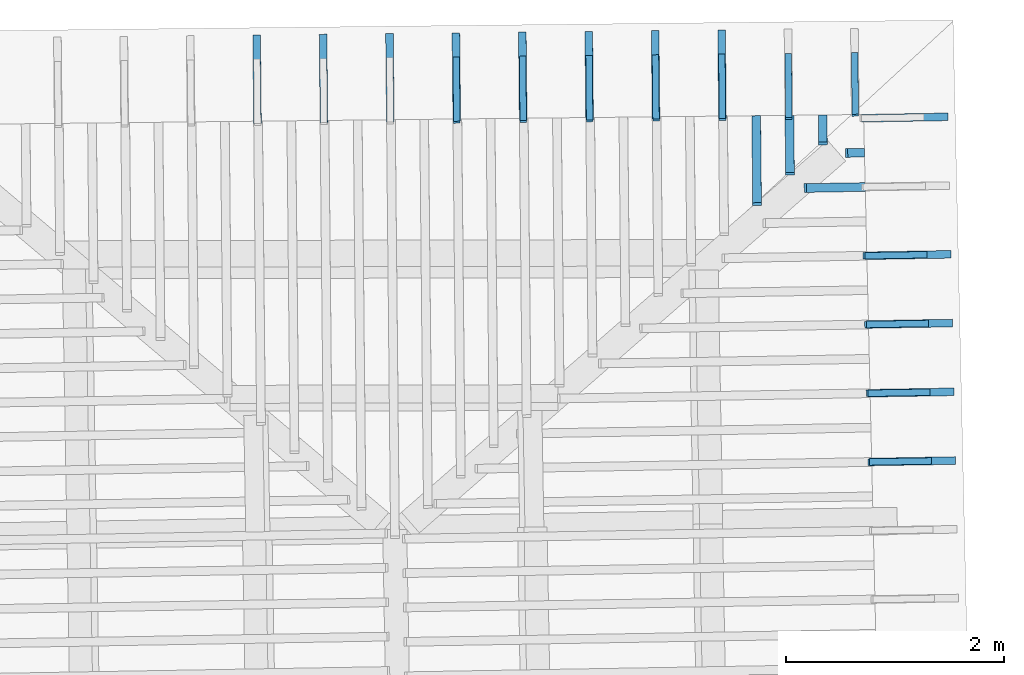
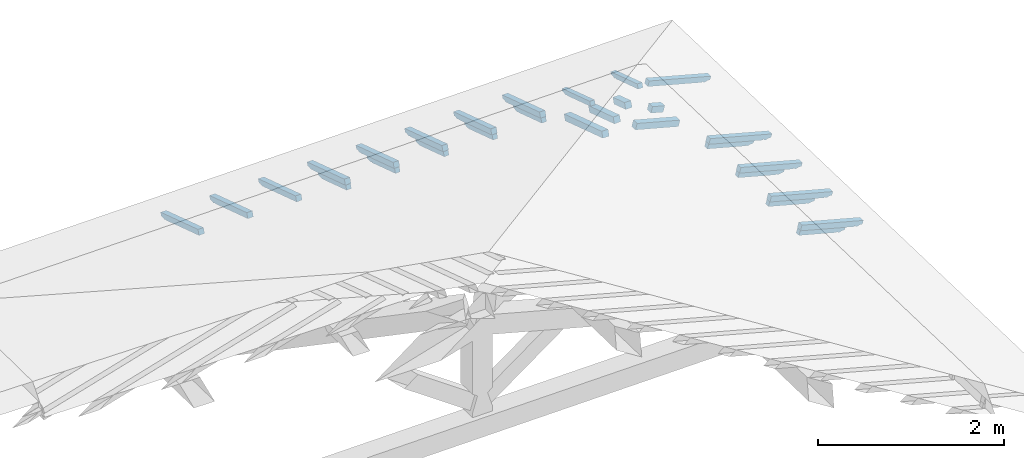
# One storey, part 16 of 19: 29 beams, 6 elements without a shape of their own.
"""IFC4 building model written with IfcOpenShell, lengths in metres."""

from ifc_helpers import new_model, entity, si_unit, converted_unit, derived_unit, direction, frame, origin, place, context, subcontext, project, spatial, line, arc, indexed_curve, outline, extrude, source, transform, mapped, material, type_object, type_shapes, element, aggregate, save


model = new_model("IFC4")

# Units and contexts
model_context = context("Model", 3, precision=1e-05, world=origin(), true_north=direction((6.123233995736766e-17, 1.0)))
body_context = subcontext(model_context, "Body", "Model", "MODEL_VIEW")
ifc_project = project(units=[si_unit("LENGTHUNIT", "METRE"), si_unit("AREAUNIT", "SQUARE_METRE"), si_unit("VOLUMEUNIT", "CUBIC_METRE"), converted_unit("PLANEANGLEUNIT", "DEGREE", entity("IfcPlaneAngleMeasure", 0.017453292519943278), si_unit("PLANEANGLEUNIT", "RADIAN"), dimensions=[0, 0, 0, 0, 0, 0, 0]), derived_unit("THERMALTRANSMITTANCEUNIT", [(si_unit("MASSUNIT", "GRAM", prefix="KILO"), 1), (si_unit("THERMODYNAMICTEMPERATUREUNIT", "KELVIN"), -1), (si_unit("TIMEUNIT", "SECOND"), -3)])], contexts=[model_context])

# Site, building, storey
site_placement = place(None, origin())
site = spatial("IfcSite", under=ifc_project, at=site_placement, CompositionType="ELEMENT")
building_placement = place(site_placement, origin())
building = spatial("IfcBuilding", under=site, at=building_placement, CompositionType="ELEMENT")
storey_placement = place(building_placement, frame((0.0, 0.0, 3.28)))
storey = spatial("IfcBuildingStorey", under=building, at=storey_placement, Name="Livello Copertura", CompositionType="ELEMENT", Elevation=3.28)

# Assembly, beams
assembly_1_placement = place(storey_placement, origin())
assembly_1 = element("IfcElementAssembly", 1, at=assembly_1_placement, inside=storey, Name="Sistema di travi strutturali:Sistema di travi strutturali", ObjectType="Sistema di travi strutturali:Sistema di travi strutturali", AssemblyPlace="NOTDEFINED", PredefinedType="BEAM_GRID")
ifc_material = material(Name="Legno - Legno da costruzione", Category="Legno")
beam_type_1 = type_object("IfcBeamType", Name="Legno:80x80", PredefinedType="JOIST", material=ifc_material)
shared_shape_1 = source(origin(), body_context, "Body", "SweptSolid", [
    extrude(outline(indexed_curve([(-0.279, -0.04000000000000169), (0.279, -0.04000000000000169), (0.279, 0.04000000000000169), (-0.279, 0.04000000000000169), (-0.279, -0.04000000000000169)], self_intersect=False)), frame((0.0, 0.0, -0.040000000000005476), z_axis=(0.0, 0.0, 1.0), x_axis=(-1.0, 0.0, 0.0)), (0.0, 0.0, 1.0), 0.07999999999999997),
])
type_shapes(beam_type_1, [shared_shape_1])
beam_1_placement = place(assembly_1_placement, frame((3.7267769633071848, 15.508499100327318, 0.1833482961653332), z_axis=(0.2688805697492533, 0.004594467440668275, 0.9631625667976583), x_axis=(-0.9630219859926787, -0.01645553326302891, 0.2689198206152652)))
beam_1 = element("IfcBeam", 2, at=beam_1_placement, type_object=beam_type_1, material=ifc_material, Name="Legno:80x80", ObjectType="Legno:80x80", PredefinedType="JOIST", context=body_context, shape_type="MappedRepresentation", body=[
    mapped(shared_shape_1, transform((0.0, 0.0, 0.0), scale=1.0)),
])
beam_type_2 = type_object("IfcBeamType", Name="Legno:80x80", PredefinedType="JOIST", material=ifc_material)
shared_shape_2 = source(origin(), body_context, "Body", "SweptSolid", [
    extrude(outline(indexed_curve([(-0.0795, -0.04000000000000169), (0.0795, -0.04000000000000169), (0.0795, 0.04000000000000169), (-0.0795, 0.04000000000000169), (-0.0795, -0.04000000000000169)], self_intersect=False)), frame((0.0, 0.0, -0.040000000000005476), z_axis=(0.0, 0.0, 1.0), x_axis=(-1.0, 0.0, 0.0)), (0.0, 0.0, 1.0), 0.07999999999999997),
])
type_shapes(beam_type_2, [shared_shape_2])
beam_2_placement = place(assembly_1_placement, frame((3.911529097117248, 15.826702015610415, 0.13025421454517638), z_axis=(0.26888056974925423, 0.00459446744066829, 0.963162566797658), x_axis=(-0.9630219859926784, -0.01645553326302434, 0.26891982061526615)))
beam_2 = element("IfcBeam", 3, at=beam_2_placement, type_object=beam_type_2, material=ifc_material, Name="Legno:80x80", ObjectType="Legno:80x80", PredefinedType="JOIST", context=body_context, shape_type="MappedRepresentation", body=[
    mapped(shared_shape_2, transform((0.0, 0.0, 0.0), scale=1.0)),
])
aggregate(assembly_1, [beam_1, beam_2])

assembly_2_placement = place(storey_placement, origin())
assembly_2 = element("IfcElementAssembly", 4, at=assembly_2_placement, inside=storey, Name="Sistema di travi strutturali:Sistema di travi strutturali", ObjectType="Sistema di travi strutturali:Sistema di travi strutturali", AssemblyPlace="NOTDEFINED", PredefinedType="BEAM_GRID")
beam_type_3 = type_object("IfcBeamType", Name="Legno:80x80", PredefinedType="JOIST", material=ifc_material)
shared_shape_3 = source(origin(), body_context, "Body", "SweptSolid", [
    extrude(outline(indexed_curve([(-0.418, -0.04000000000000169), (0.418, -0.04000000000000169), (0.418, 0.04000000000000169), (-0.418, 0.04000000000000169), (-0.418, -0.04000000000000169)], self_intersect=False)), frame((0.0, 0.0, -0.040000000000005476), z_axis=(0.0, 0.0, 1.0), x_axis=(-1.0, 0.0, 0.0)), (0.0, 0.0, 1.0), 0.07999999999999997),
])
type_shapes(beam_type_3, [shared_shape_3])
beam_3_placement = place(assembly_2_placement, frame((3.0112670167660958, 15.755773925866922, 0.2601151669695332), z_axis=(-0.007186655942142936, 0.3016187585889335, 0.953401529495123), x_axis=(0.009276659863625766, -0.95336501447268, 0.3016771333085781)))
beam_3 = element("IfcBeam", 5, at=beam_3_placement, type_object=beam_type_3, material=ifc_material, Name="Legno:80x80", ObjectType="Legno:80x80", PredefinedType="JOIST", context=body_context, shape_type="MappedRepresentation", body=[
    mapped(shared_shape_3, transform((0.0, 0.0, 0.0), scale=1.0)),
])
beam_type_4 = type_object("IfcBeamType", Name="Legno:80x80", PredefinedType="JOIST", material=ifc_material)
shared_shape_4 = source(origin(), body_context, "Body", "SweptSolid", [
    extrude(outline(indexed_curve([(-0.2745, -0.04000000000000169), (0.2745, -0.04000000000000169), (0.2745, 0.04000000000000169), (-0.2745, 0.04000000000000169), (-0.2745, -0.04000000000000169)], self_intersect=False)), frame((0.0, 0.0, -0.040000000000005476), z_axis=(0.0, 0.0, 1.0), x_axis=(-1.0, 0.0, 0.0)), (0.0, 0.0, 1.0), 0.07999999999999997),
])
type_shapes(beam_type_4, [shared_shape_4])
beam_4_placement = place(assembly_2_placement, frame((3.3142121722066498, 15.896209486026077, 0.21797045094759238), z_axis=(-0.0071866559421429315, 0.30161875858893306, 0.9534015294951231), x_axis=(0.009276659863625941, -0.9533650144726801, 0.30167713330857765)))
beam_4 = element("IfcBeam", 6, at=beam_4_placement, type_object=beam_type_4, material=ifc_material, Name="Legno:80x80", ObjectType="Legno:80x80", PredefinedType="JOIST", context=body_context, shape_type="MappedRepresentation", body=[
    mapped(shared_shape_4, transform((0.0, 0.0, 0.0), scale=1.0)),
])
beam_type_5 = type_object("IfcBeamType", Name="Legno:80x80", PredefinedType="JOIST", material=ifc_material)
shared_shape_5 = source(origin(), body_context, "Body", "SweptSolid", [
    extrude(outline(indexed_curve([(-0.1305, -0.04000000000000169), (0.1305, -0.04000000000000169), (0.1305, 0.04000000000000169), (-0.1305, 0.04000000000000169), (-0.1305, -0.04000000000000169)], self_intersect=False)), frame((0.0, 0.0, -0.040000000000005476), z_axis=(0.0, 0.0, 1.0), x_axis=(-1.0, 0.0, 0.0)), (0.0, 0.0, 1.0), 0.07999999999999997),
])
type_shapes(beam_type_5, [shared_shape_5])
beam_5_placement = place(assembly_2_placement, frame((3.6171573276472038, 16.03664504618524, 0.17582573492565068), z_axis=(-0.007186655942142942, 0.3016187585889341, 0.9534015294951228), x_axis=(0.009276659863626574, -0.9533650144726795, 0.30167713330857876)))
beam_5 = element("IfcBeam", 7, at=beam_5_placement, type_object=beam_type_5, material=ifc_material, Name="Legno:80x80", ObjectType="Legno:80x80", PredefinedType="JOIST", context=body_context, shape_type="MappedRepresentation", body=[
    mapped(shared_shape_5, transform((0.0, 0.0, 0.0), scale=1.0)),
])
aggregate(assembly_2, [beam_3, beam_4, beam_5])

assembly_3_placement = place(storey_placement, origin())
assembly_3 = element("IfcElementAssembly", 8, at=assembly_3_placement, inside=storey, Name="Sistema di travi strutturali:Sistema di travi strutturali", ObjectType="Sistema di travi strutturali:Sistema di travi strutturali", AssemblyPlace="NOTDEFINED", PredefinedType="BEAM_GRID")
beam_type_6 = type_object("IfcBeamType", Name="70x70:70x70", PredefinedType="JOIST", material=ifc_material)
shared_shape_6 = source(origin(), body_context, "Body", "SweptSolid", [
    extrude(outline(indexed_curve([(-0.04357142857143151, -0.5561428571428565), (0.026428571428568467, -0.5561428571428565), (0.026428571428568467, 0.1728571428571433), (0.012428571428584355, 0.1728571428571399), (0.026181867029378872, 0.19656674738504454), (0.018428571428570788, 0.22285714285714342), (0.006014118110847752, 0.24585271837212633), (0.0034285714285709526, 0.27185714285714324), (-0.04357142857143151, 0.27185714285714324)], segments=[line(1, 2, 3, 4), arc(4, 5, 6), arc(6, 7, 8), line(8, 9, 1)], self_intersect=False)), frame((-0.10714285714285654, -0.03500000000000078, -0.008571428571433252), z_axis=(0.0, 1.0, 0.0), x_axis=(0.0, 0.0, -1.0)), (0.0, 0.0, 1.0), 0.06999999999999999),
])
type_shapes(beam_type_6, [shared_shape_6])
beam_6_placement = place(assembly_3_placement, frame((-1.5663396586173428, 16.53427274474894, 0.11772482123685446), z_axis=(-0.007186655942142927, 0.30161875858893367, 0.953401529495123), x_axis=(0.009276659863625813, -0.9533650144726797, 0.3016771333085783)))
beam_6 = element("IfcBeam", 9, at=beam_6_placement, type_object=beam_type_6, material=ifc_material, Name="70x70:70x70", ObjectType="70x70:70x70", PredefinedType="JOIST", context=body_context, shape_type="MappedRepresentation", body=[
    mapped(shared_shape_6, transform((0.0, 0.0, 0.0), scale=1.0)),
])
beam_7_placement = place(assembly_3_placement, frame((-0.957781563521672, 16.540974910538722, 0.1201917762942184), z_axis=(-0.007186655942142937, 0.30161875858893444, 0.9534015294951228), x_axis=(0.009276659863625778, -0.9533650144726795, 0.3016771333085791)))
beam_7 = element("IfcBeam", 10, at=beam_7_placement, type_object=beam_type_6, material=ifc_material, Name="70x70:70x70", ObjectType="70x70:70x70", PredefinedType="JOIST", context=body_context, shape_type="MappedRepresentation", body=[
    mapped(shared_shape_6, transform((0.0, 0.0, 0.0), scale=1.0)),
])
beam_8_placement = place(assembly_3_placement, frame((-0.3492234684260014, 16.547677076328508, 0.12265873135158412), z_axis=(-0.007186655942142923, 0.3016187585889333, 0.9534015294951231), x_axis=(0.009276659863625625, -0.95336501447268, 0.30167713330857787)))
beam_8 = element("IfcBeam", 11, at=beam_8_placement, type_object=beam_type_6, material=ifc_material, Name="70x70:70x70", ObjectType="70x70:70x70", PredefinedType="JOIST", context=body_context, shape_type="MappedRepresentation", body=[
    mapped(shared_shape_6, transform((0.0, 0.0, 0.0), scale=1.0)),
])
beam_9_placement = place(assembly_3_placement, frame((0.2593346266696697, 16.554379242118284, 0.12512568640894806), z_axis=(-0.007186655942142926, 0.30161875858893383, 0.9534015294951229), x_axis=(0.009276659863625643, -0.9533650144726799, 0.3016771333085784)))
beam_9 = element("IfcBeam", 12, at=beam_9_placement, type_object=beam_type_6, material=ifc_material, Name="70x70:70x70", ObjectType="70x70:70x70", PredefinedType="JOIST", context=body_context, shape_type="MappedRepresentation", body=[
    mapped(shared_shape_6, transform((0.0, 0.0, 0.0), scale=1.0)),
])
beam_10_placement = place(assembly_3_placement, frame((0.8678927217653406, 16.56108140790806, 0.12759264146631555), z_axis=(-0.007186655942142923, 0.30161875858893333, 0.9534015294951231), x_axis=(0.009276659863625738, -0.95336501447268, 0.3016771333085779)))
beam_10 = element("IfcBeam", 13, at=beam_10_placement, type_object=beam_type_6, material=ifc_material, Name="70x70:70x70", ObjectType="70x70:70x70", PredefinedType="JOIST", context=body_context, shape_type="MappedRepresentation", body=[
    mapped(shared_shape_6, transform((0.0, 0.0, 0.0), scale=1.0)),
])
beam_11_placement = place(assembly_3_placement, frame((1.4764508168610124, 16.56778357369784, 0.13005959652368038), z_axis=(-0.007186655942142924, 0.3016187585889334, 0.9534015294951231), x_axis=(0.009276659863625681, -0.95336501447268, 0.301677133308578)))
beam_11 = element("IfcBeam", 14, at=beam_11_placement, type_object=beam_type_6, material=ifc_material, Name="70x70:70x70", ObjectType="70x70:70x70", PredefinedType="JOIST", context=body_context, shape_type="MappedRepresentation", body=[
    mapped(shared_shape_6, transform((0.0, 0.0, 0.0), scale=1.0)),
])
beam_12_placement = place(assembly_3_placement, frame((2.0850089119566815, 16.574485739487614, 0.13252655158104787), z_axis=(-0.0071866559421429315, 0.3016187585889341, 0.9534015294951229), x_axis=(0.009276659863625797, -0.9533650144726797, 0.3016771333085787)))
beam_12 = element("IfcBeam", 15, at=beam_12_placement, type_object=beam_type_6, material=ifc_material, Name="70x70:70x70", ObjectType="70x70:70x70", PredefinedType="JOIST", context=body_context, shape_type="MappedRepresentation", body=[
    mapped(shared_shape_6, transform((0.0, 0.0, 0.0), scale=1.0)),
])
beam_13_placement = place(assembly_3_placement, frame((2.6935670070523523, 16.58118790527739, 0.13499350663841536), z_axis=(-0.0071866559421429315, 0.30161875858893405, 0.9534015294951229), x_axis=(0.009276659863625587, -0.9533650144726796, 0.3016771333085787)))
beam_13 = element("IfcBeam", 16, at=beam_13_placement, type_object=beam_type_6, material=ifc_material, Name="70x70:70x70", ObjectType="70x70:70x70", PredefinedType="JOIST", context=body_context, shape_type="MappedRepresentation", body=[
    mapped(shared_shape_6, transform((0.0, 0.0, 0.0), scale=1.0)),
])
aggregate(assembly_3, [beam_6, beam_7, beam_8, beam_9, beam_10, beam_11, beam_12, beam_13])

assembly_4_placement = place(storey_placement, origin())
assembly_4 = element("IfcElementAssembly", 17, at=assembly_4_placement, inside=storey, Name="Sistema di travi strutturali:Sistema di travi strutturali", ObjectType="Sistema di travi strutturali:Sistema di travi strutturali", AssemblyPlace="NOTDEFINED", PredefinedType="BEAM_GRID")
beam_type_7 = type_object("IfcBeamType", Name="60x60:60x60", PredefinedType="JOIST", material=ifc_material)
shared_shape_7 = source(origin(), body_context, "Body", "SweptSolid", [
    extrude(outline(indexed_curve([(-0.035857142857117906, -0.404857142857143), (0.02414285714288207, -0.404857142857143), (0.02414285714288207, 0.11414285714285698), (0.007142857142882135, 0.11414285714285698), (0.02280031419839907, 0.1317392731984247), (0.02014285714279438, 0.1551428571428581), (0.006097362558745583, 0.1832964455908379), (-0.003857142857204834, 0.21314285714285694), (-0.035857142857117906, 0.21314285714285702)], segments=[line(1, 2, 3, 4), arc(4, 5, 6), arc(6, 7, 8), line(8, 9, 1)], self_intersect=False)), frame((0.04414285714285706, -0.030000000000000786, -0.005857142857119645), z_axis=(0.0, 1.0, 0.0), x_axis=(0.0, 0.0, -1.0)), (0.0, 0.0, 1.0), 0.059999999999999984),
])
type_shapes(beam_type_7, [shared_shape_7])
beam_14_placement = place(assembly_4_placement, frame((0.2598017593059092, 16.534774022809998, 0.06315458699176357), z_axis=(-0.007186655942142926, 0.30161875858893383, 0.953401529495123), x_axis=(0.009276659863625643, -0.9533650144726799, 0.3016771333085784)))
beam_14 = element("IfcBeam", 18, at=beam_14_placement, type_object=beam_type_7, material=ifc_material, Name="60x60:60x60", ObjectType="60x60:60x60", PredefinedType="JOIST", context=body_context, shape_type="MappedRepresentation", body=[
    mapped(shared_shape_7, transform((0.0, 0.0, 0.0), scale=1.0)),
])
beam_15_placement = place(assembly_4_placement, frame((0.8683598544015797, 16.541476188599777, 0.0656215420491284), z_axis=(-0.00718665594214292, 0.30161875858893333, 0.9534015294951231), x_axis=(0.009276659863625738, -0.95336501447268, 0.3016771333085779)))
beam_15 = element("IfcBeam", 19, at=beam_15_placement, type_object=beam_type_7, material=ifc_material, Name="60x60:60x60", ObjectType="60x60:60x60", PredefinedType="JOIST", context=body_context, shape_type="MappedRepresentation", body=[
    mapped(shared_shape_7, transform((0.0, 0.0, 0.0), scale=1.0)),
])
beam_16_placement = place(assembly_4_placement, frame((1.4769179494972517, 16.548178354389556, 0.06808849710649412), z_axis=(-0.007186655942142921, 0.3016187585889334, 0.9534015294951231), x_axis=(0.009276659863625681, -0.95336501447268, 0.301677133308578)))
beam_16 = element("IfcBeam", 20, at=beam_16_placement, type_object=beam_type_7, material=ifc_material, Name="60x60:60x60", ObjectType="60x60:60x60", PredefinedType="JOIST", context=body_context, shape_type="MappedRepresentation", body=[
    mapped(shared_shape_7, transform((0.0, 0.0, 0.0), scale=1.0)),
])
beam_17_placement = place(assembly_4_placement, frame((2.0854760445929212, 16.554880520179335, 0.07055545216385983), z_axis=(-0.007186655942142929, 0.3016187585889341, 0.9534015294951229), x_axis=(0.009276659863625797, -0.9533650144726797, 0.3016771333085787)))
beam_17 = element("IfcBeam", 21, at=beam_17_placement, type_object=beam_type_7, material=ifc_material, Name="60x60:60x60", ObjectType="60x60:60x60", PredefinedType="JOIST", context=body_context, shape_type="MappedRepresentation", body=[
    mapped(shared_shape_7, transform((0.0, 0.0, 0.0), scale=1.0)),
])
beam_18_placement = place(assembly_4_placement, frame((2.694034139688592, 16.56158268596911, 0.07302240722122821), z_axis=(-0.00718665594214293, 0.30161875858893405, 0.9534015294951229), x_axis=(0.009276659863625587, -0.9533650144726796, 0.3016771333085787)))
beam_18 = element("IfcBeam", 22, at=beam_18_placement, type_object=beam_type_7, material=ifc_material, Name="60x60:60x60", ObjectType="60x60:60x60", PredefinedType="JOIST", context=body_context, shape_type="MappedRepresentation", body=[
    mapped(shared_shape_7, transform((0.0, 0.0, 0.0), scale=1.0)),
])
beam_19_placement = place(assembly_4_placement, frame((3.302592234784264, 16.568284851758882, 0.07548936227859393), z_axis=(-0.007186655942142923, 0.30161875858893344, 0.9534015294951231), x_axis=(0.00927665986362566, -0.95336501447268, 0.30167713330857804)))
beam_19 = element("IfcBeam", 23, at=beam_19_placement, type_object=beam_type_7, material=ifc_material, Name="60x60:60x60", ObjectType="60x60:60x60", PredefinedType="JOIST", context=body_context, shape_type="MappedRepresentation", body=[
    mapped(shared_shape_7, transform((0.0, 0.0, 0.0), scale=1.0)),
])
beam_type_8 = type_object("IfcBeamType", Name="60x60:60x60", PredefinedType="JOIST", material=ifc_material)
shared_shape_8 = source(origin(), body_context, "Body", "SweptSolid", [
    extrude(outline(indexed_curve([(-0.03585714285711789, -0.38700000000000007), (0.02414285714288209, -0.38700000000000007), (0.02414285714288209, 0.1069999999999998), (0.007142857142882154, 0.1069999999999998), (0.022800314198399084, 0.12459641605556755), (0.02014285714279433, 0.14800000000000094), (0.0060973625587455345, 0.1761535884479807), (-0.0038571428572048826, 0.20599999999999977), (-0.03585714285711789, 0.20599999999999985)], segments=[line(1, 2, 3, 4), arc(4, 5, 6), arc(6, 7, 8), line(8, 9, 1)], self_intersect=False)), frame((0.04949999999999989, -0.030000000000000786, -0.005857142857119626), z_axis=(0.0, 1.0, 0.0), x_axis=(0.0, 0.0, -1.0)), (0.0, 0.0, 1.0), 0.059999999999999984),
])
type_shapes(beam_type_8, [shared_shape_8])
beam_20_placement = place(assembly_4_placement, frame((3.9110335180243188, 16.586991805700578, 0.07415759384530496), z_axis=(-0.0071866559421429246, 0.3016187585889337, 0.953401529495123), x_axis=(0.009276659863625414, -0.9533650144726799, 0.3016771333085783)))
beam_20 = element("IfcBeam", 24, at=beam_20_placement, type_object=beam_type_8, material=ifc_material, Name="60x60:60x60", ObjectType="60x60:60x60", PredefinedType="JOIST", context=body_context, shape_type="MappedRepresentation", body=[
    mapped(shared_shape_8, transform((0.0, 0.0, 0.0), scale=1.0)),
])
aggregate(assembly_4, [beam_14, beam_15, beam_16, beam_17, beam_18, beam_19, beam_20])

assembly_5_placement = place(storey_placement, origin())
assembly_5 = element("IfcElementAssembly", 25, at=assembly_5_placement, inside=storey, Name="Sistema di travi strutturali:Sistema di travi strutturali", ObjectType="Sistema di travi strutturali:Sistema di travi strutturali", AssemblyPlace="NOTDEFINED", PredefinedType="BEAM_GRID")
beam_type_9 = type_object("IfcBeamType", Name="70x70:70x70", PredefinedType="JOIST", material=ifc_material)
shared_shape_9 = source(origin(), body_context, "Body", "SweptSolid", [
    extrude(outline(indexed_curve([(-0.04357142857143151, -0.5375714285714281), (0.026428571428568488, -0.5375714285714281), (0.026428571428568488, 0.16542857142857195), (0.01242857142858439, 0.16542857142856862), (0.026181867029378907, 0.18913817595647325), (0.01842857142857074, 0.2154285714285721), (0.0060141181108477005, 0.23842414694355502), (0.0034285714285709062, 0.2644285714285719), (-0.04357142857143151, 0.2644285714285719)], segments=[line(1, 2, 3, 4), arc(4, 5, 6), arc(6, 7, 8), line(8, 9, 1)], self_intersect=False)), frame((-0.10157142857142812, -0.03500000000000078, -0.008571428571433235), z_axis=(0.0, 1.0, 0.0), x_axis=(0.0, 0.0, -1.0)), (0.0, 0.0, 1.0), 0.06999999999999999),
])
type_shapes(beam_type_9, [shared_shape_9])
beam_21_placement = place(assembly_5_placement, frame((4.401955255169358, 16.150128102479133, 0.1290458611018519), z_axis=(0.268880569749254, 0.004594467440668782, 0.9631625667976581), x_axis=(-0.9630219859926784, -0.016455533263031324, 0.268919820615266)))
beam_21 = element("IfcBeam", 26, at=beam_21_placement, type_object=beam_type_9, material=ifc_material, Name="70x70:70x70", ObjectType="70x70:70x70", PredefinedType="JOIST", context=body_context, shape_type="MappedRepresentation", body=[
    mapped(shared_shape_9, transform((0.0, 0.0, 0.0), scale=1.0)),
])
beam_type_10 = type_object("IfcBeamType", Name="70x70:70x70", PredefinedType="JOIST", material=ifc_material)
shared_shape_10 = source(origin(), body_context, "Body", "SweptSolid", [
    extrude(outline(indexed_curve([(-0.043571428571431446, -0.5361428571428567), (0.026428571428568543, -0.5361428571428567), (0.026428571428568543, 0.16485714285714334), (0.012428571428584445, 0.16485714285713995), (0.026181867029378962, 0.18856674738504461), (0.018428571428570607, 0.2148571428571435), (0.0060141181108475696, 0.2378527183721264), (0.003428571428570775, 0.2638571428571433), (-0.043571428571431446, 0.2638571428571433)], segments=[line(1, 2, 3, 4), arc(4, 5, 6), arc(6, 7, 8), line(8, 9, 1)], self_intersect=False)), frame((-0.10114285714285667, -0.03500000000000078, -0.008571428571433181), z_axis=(0.0, 1.0, 0.0), x_axis=(0.0, 0.0, -1.0)), (0.0, 0.0, 1.0), 0.06999999999999999),
])
type_shapes(beam_type_10, [shared_shape_10])
beam_22_placement = place(assembly_5_placement, frame((4.430851268322206, 14.890437926653112, 0.12698808700412556), z_axis=(0.26888056974925334, 0.004594467440668772, 0.9631625667976583), x_axis=(-0.9630219859926786, -0.01645553326303286, 0.2689198206152653)))
beam_22 = element("IfcBeam", 27, at=beam_22_placement, type_object=beam_type_10, material=ifc_material, Name="70x70:70x70", ObjectType="70x70:70x70", PredefinedType="JOIST", context=body_context, shape_type="MappedRepresentation", body=[
    mapped(shared_shape_10, transform((0.0, 0.0, 0.0), scale=1.0)),
])
beam_type_11 = type_object("IfcBeamType", Name="70x70:70x70", PredefinedType="JOIST", material=ifc_material)
shared_shape_11 = source(origin(), body_context, "Body", "SweptSolid", [
    extrude(outline(indexed_curve([(-0.04357142857143151, -0.535428571428571), (0.026428571428568484, -0.535428571428571), (0.026428571428568484, 0.16457142857142906), (0.012428571428584384, 0.16457142857142568), (0.026181867029378903, 0.1882810330993303), (0.01842857142857075, 0.2145714285714292), (0.006014118110847714, 0.2375670040864121), (0.0034285714285709197, 0.263571428571429), (-0.04357142857143151, 0.263571428571429)], segments=[line(1, 2, 3, 4), arc(4, 5, 6), arc(6, 7, 8), line(8, 9, 1)], self_intersect=False)), frame((-0.10092857142857095, -0.03500000000000078, -0.008571428571433238), z_axis=(0.0, 1.0, 0.0), x_axis=(0.0, 0.0, -1.0)), (0.0, 0.0, 1.0), 0.06999999999999999),
])
type_shapes(beam_type_11, [shared_shape_11])
beam_23_placement = place(assembly_5_placement, frame((4.445299274898629, 14.2605928387401, 0.12595919995526295), z_axis=(0.26888056974925356, 0.0045944674406687746, 0.9631625667976583), x_axis=(-0.9630219859926785, -0.01645553326303362, 0.2689198206152655)))
beam_23 = element("IfcBeam", 28, at=beam_23_placement, type_object=beam_type_11, material=ifc_material, Name="70x70:70x70", ObjectType="70x70:70x70", PredefinedType="JOIST", context=body_context, shape_type="MappedRepresentation", body=[
    mapped(shared_shape_11, transform((0.0, 0.0, 0.0), scale=1.0)),
])
beam_24_placement = place(assembly_5_placement, frame((4.459747281475052, 13.630747750827087, 0.12493031290639811), z_axis=(0.268880569749253, 0.004594467440668763, 0.9631625667976584), x_axis=(-0.9630219859926786, -0.01645553326303192, 0.2689198206152649)))
beam_24 = element("IfcBeam", 29, at=beam_24_placement, type_object=beam_type_11, material=ifc_material, Name="70x70:70x70", ObjectType="70x70:70x70", PredefinedType="JOIST", context=body_context, shape_type="MappedRepresentation", body=[
    mapped(shared_shape_11, transform((0.0, 0.0, 0.0), scale=1.0)),
])
beam_type_12 = type_object("IfcBeamType", Name="70x70:70x70", PredefinedType="JOIST", material=ifc_material)
shared_shape_12 = source(origin(), body_context, "Body", "SweptSolid", [
    extrude(outline(indexed_curve([(-0.043571428571431446, -0.5347142857142851), (0.02642857142856851, -0.5347142857142851), (0.02642857142856851, 0.1642857142857147), (0.012428571428584397, 0.16428571428571134), (0.026181867029378917, 0.187995318813616), (0.01842857142857066, 0.21428571428571486), (0.006014118110847623, 0.23728128980069776), (0.0034285714285708247, 0.2632857142857147), (-0.043571428571431446, 0.2632857142857148)], segments=[line(1, 2, 3, 4), arc(4, 5, 6), arc(6, 7, 8), line(8, 9, 1)], self_intersect=False)), frame((-0.10071428571428516, -0.03500000000000078, -0.00857142857143321), z_axis=(0.0, 1.0, 0.0), x_axis=(0.0, 0.0, -1.0)), (0.0, 0.0, 1.0), 0.06999999999999999),
])
type_shapes(beam_type_12, [shared_shape_12])
beam_25_placement = place(assembly_5_placement, frame((4.474195288051477, 13.000902662914074, 0.12390142585753461), z_axis=(0.26888056974925395, 0.0045944674406687815, 0.9631625667976581), x_axis=(-0.9630219859926785, -0.0164555332630302, 0.2689198206152659)))
beam_25 = element("IfcBeam", 30, at=beam_25_placement, type_object=beam_type_12, material=ifc_material, Name="70x70:70x70", ObjectType="70x70:70x70", PredefinedType="JOIST", context=body_context, shape_type="MappedRepresentation", body=[
    mapped(shared_shape_12, transform((0.0, 0.0, 0.0), scale=1.0)),
])
aggregate(assembly_5, [beam_21, beam_22, beam_23, beam_24, beam_25])

assembly_6_placement = place(storey_placement, origin())
assembly_6 = element("IfcElementAssembly", 31, at=assembly_6_placement, inside=storey, Name="Sistema di travi strutturali:Sistema di travi strutturali", ObjectType="Sistema di travi strutturali:Sistema di travi strutturali", AssemblyPlace="NOTDEFINED", PredefinedType="BEAM_GRID")
beam_type_13 = type_object("IfcBeamType", Name="60x60:60x60", PredefinedType="JOIST", material=ifc_material)
shared_shape_13 = source(origin(), body_context, "Body", "SweptSolid", [
    extrude(outline(indexed_curve([(-0.035857142857117726, -0.38485714285714306), (0.024142857142882255, -0.38485714285714306), (0.024142857142882255, 0.10614285714285701), (0.007142857142882318, 0.10614285714285701), (0.02280031419839925, 0.12373927319842472), (0.02014285714279392, 0.14714285714285813), (0.0060973625587451225, 0.17529644559083793), (-0.003857142857205294, 0.20514285714285696), (-0.035857142857117726, 0.20514285714285704)], segments=[line(1, 2, 3, 4), arc(4, 5, 6), arc(6, 7, 8), line(8, 9, 1)], self_intersect=False)), frame((0.050142857142857, -0.030000000000000786, -0.005857142857119462), z_axis=(0.0, 1.0, 0.0), x_axis=(0.0, 0.0, -1.0)), (0.0, 0.0, 1.0), 0.059999999999999984),
])
type_shapes(beam_type_13, [shared_shape_13])
beam_26_placement = place(assembly_6_placement, frame((4.413374031288504, 14.89013928626947, 0.06438252016227719), z_axis=(0.26888056974925334, 0.004594467440668773, 0.9631625667976583), x_axis=(-0.9630219859926786, -0.01645553326303286, 0.2689198206152653)))
beam_26 = element("IfcBeam", 32, at=beam_26_placement, type_object=beam_type_13, material=ifc_material, Name="60x60:60x60", ObjectType="60x60:60x60", PredefinedType="JOIST", context=body_context, shape_type="MappedRepresentation", body=[
    mapped(shared_shape_13, transform((0.0, 0.0, 0.0), scale=1.0)),
])
beam_type_14 = type_object("IfcBeamType", Name="60x60:60x60", PredefinedType="JOIST", material=ifc_material)
shared_shape_14 = source(origin(), body_context, "Body", "SweptSolid", [
    extrude(outline(indexed_curve([(-0.03585714285711797, -0.38414285714285734), (0.024142857142882012, -0.38414285714285734), (0.024142857142882012, 0.1058571428571427), (0.007142857142882077, 0.1058571428571427), (0.02280031419839901, 0.12345355891271044), (0.020142857142794526, 0.14685714285714382), (0.006097362558745728, 0.17501073130512362), (-0.003857142857204689, 0.20485714285714265), (-0.03585714285711797, 0.2048571428571427)], segments=[line(1, 2, 3, 4), arc(4, 5, 6), arc(6, 7, 8), line(8, 9, 1)], self_intersect=False)), frame((0.05035714285714273, -0.030000000000000786, -0.005857142857119703), z_axis=(0.0, 1.0, 0.0), x_axis=(0.0, 0.0, -1.0)), (0.0, 0.0, 1.0), 0.059999999999999984),
])
type_shapes(beam_type_14, [shared_shape_14])
beam_27_placement = place(assembly_6_placement, frame((4.427822037864926, 14.260294198356458, 0.06335363311341413), z_axis=(0.2688805697492534, 0.004594467440668772, 0.9631625667976583), x_axis=(-0.9630219859926785, -0.01645553326303365, 0.26891982061526537)))
beam_27 = element("IfcBeam", 33, at=beam_27_placement, type_object=beam_type_14, material=ifc_material, Name="60x60:60x60", ObjectType="60x60:60x60", PredefinedType="JOIST", context=body_context, shape_type="MappedRepresentation", body=[
    mapped(shared_shape_14, transform((0.0, 0.0, 0.0), scale=1.0)),
])
beam_28_placement = place(assembly_6_placement, frame((4.44227004444135, 13.630449110443442, 0.06232474606455085), z_axis=(0.2688805697492534, 0.004594467440668771, 0.9631625667976583), x_axis=(-0.9630219859926785, -0.016455533263034436, 0.2689198206152653)))
beam_28 = element("IfcBeam", 34, at=beam_28_placement, type_object=beam_type_14, material=ifc_material, Name="60x60:60x60", ObjectType="60x60:60x60", PredefinedType="JOIST", context=body_context, shape_type="MappedRepresentation", body=[
    mapped(shared_shape_14, transform((0.0, 0.0, 0.0), scale=1.0)),
])
beam_type_15 = type_object("IfcBeamType", Name="60x60:60x60", PredefinedType="JOIST", material=ifc_material)
shared_shape_15 = source(origin(), body_context, "Body", "SweptSolid", [
    extrude(outline(indexed_curve([(-0.03585714285711796, -0.38342857142857156), (0.024142857142882022, -0.38342857142857156), (0.024142857142882022, 0.1055714285714284), (0.007142857142882086, 0.1055714285714284), (0.022800314198399018, 0.12316784462699615), (0.0201428571427945, 0.14657142857142952), (0.006097362558745704, 0.17472501701940932), (-0.0038571428572047135, 0.20457142857142835), (-0.03585714285711796, 0.20457142857142843)], segments=[line(1, 2, 3, 4), arc(4, 5, 6), arc(6, 7, 8), line(8, 9, 1)], self_intersect=False)), frame((0.050571428571428455, -0.030000000000000786, -0.005857142857119694), z_axis=(0.0, 1.0, 0.0), x_axis=(0.0, 0.0, -1.0)), (0.0, 0.0, 1.0), 0.059999999999999984),
])
type_shapes(beam_type_15, [shared_shape_15])
beam_29_placement = place(assembly_6_placement, frame((4.4567180510177735, 13.00060402253043, 0.061295859015688015), z_axis=(0.26888056974925306, 0.004594467440668768, 0.9631625667976583), x_axis=(-0.9630219859926787, -0.016455533263030182, 0.26891982061526504)))
beam_29 = element("IfcBeam", 35, at=beam_29_placement, type_object=beam_type_15, material=ifc_material, Name="60x60:60x60", ObjectType="60x60:60x60", PredefinedType="JOIST", context=body_context, shape_type="MappedRepresentation", body=[
    mapped(shared_shape_15, transform((0.0, 0.0, 0.0), scale=1.0)),
])
aggregate(assembly_6, [beam_26, beam_27, beam_28, beam_29])

save(model, "model.ifc")
